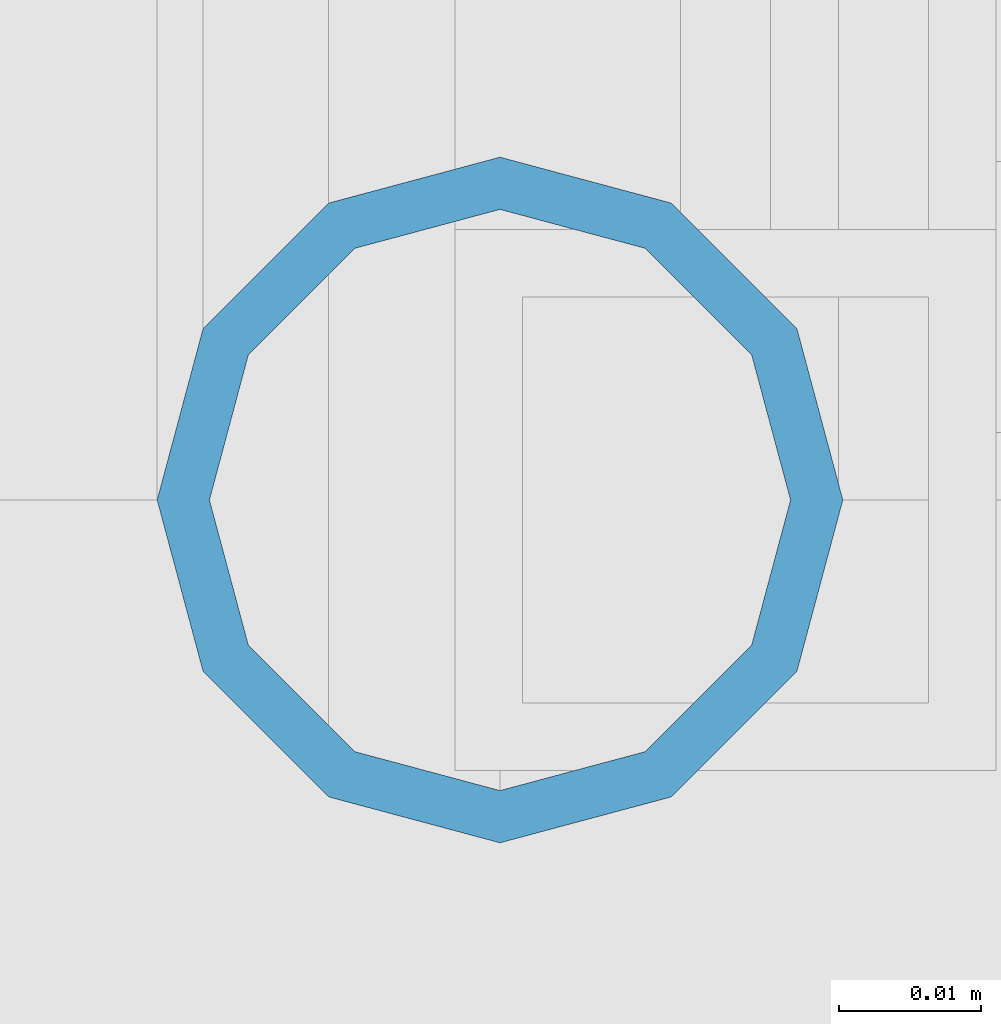
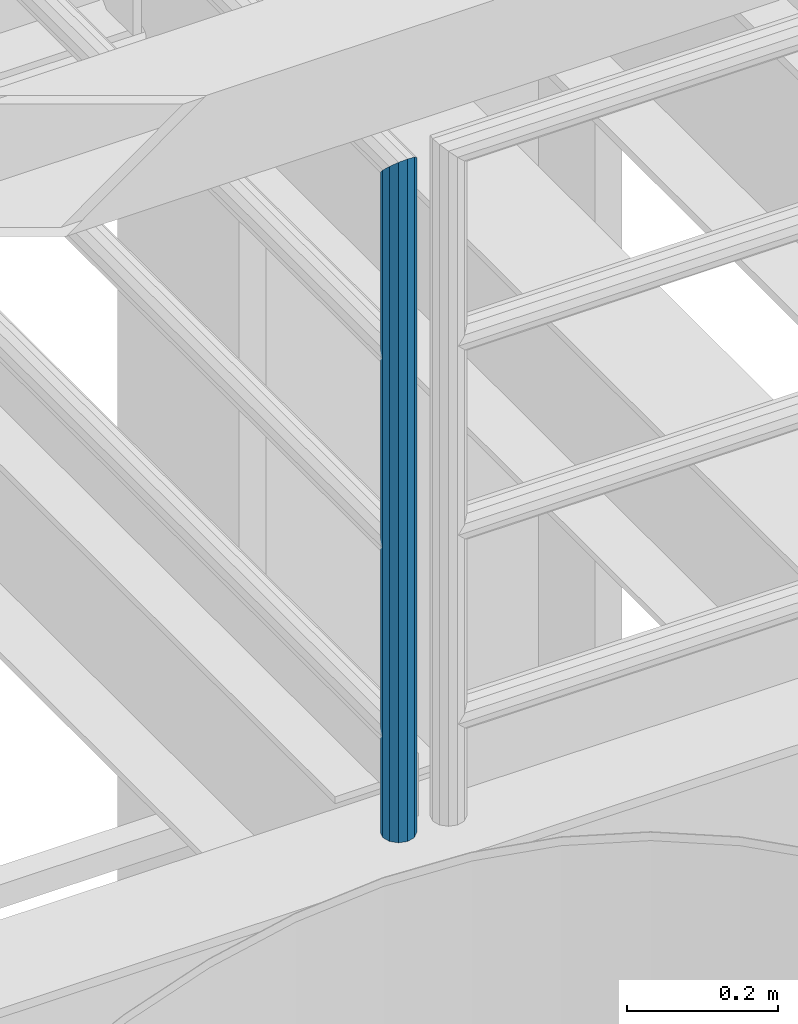
# One storey, part 586 of 1876: 1 column, 1 element without a shape of its own.
"""IFC2X3 building model written with IfcOpenShell, lengths in millimetres."""

from ifc_helpers import new_model, si_unit, frame, origin_with_axes, place, context, subcontext, project, spatial, faceted_brep, material, type_object, element, aggregate, save


model = new_model("IFC2X3")

# Units and contexts
model_context = context("Model", 3, precision=1e-05, world=origin_with_axes())
body_context = subcontext(model_context, "Body", "Model", "MODEL_VIEW")
ifc_project = project(units=[si_unit("LENGTHUNIT", "METRE", prefix="MILLI"), si_unit("AREAUNIT", "SQUARE_METRE"), si_unit("VOLUMEUNIT", "CUBIC_METRE"), si_unit("MASSUNIT", "GRAM", prefix="KILO"), si_unit("TIMEUNIT", "SECOND"), si_unit("PLANEANGLEUNIT", "RADIAN"), si_unit("SOLIDANGLEUNIT", "STERADIAN"), si_unit("THERMODYNAMICTEMPERATUREUNIT", "DEGREE_CELSIUS"), si_unit("LUMINOUSINTENSITYUNIT", "LUMEN")], contexts=[model_context])

# Site, building, storey
site_placement = place(None, origin_with_axes())
site = spatial("IfcSite", under=ifc_project, at=site_placement, CompositionType="ELEMENT")
building_placement = place(site_placement, origin_with_axes())
building = spatial("IfcBuilding", under=site, at=building_placement, Name="Undefined", CompositionType="ELEMENT")
storey_placement = place(building_placement, origin_with_axes())
storey = spatial("IfcBuildingStorey", under=building, at=storey_placement, Name="Undefined", CompositionType="ELEMENT", Elevation=0.0)

# Assembly, column
assembly_placement = place(storey_placement, origin_with_axes())
assembly = element("IfcElementAssembly", 1, at=assembly_placement, inside=storey, Name="RAIL", AssemblyPlace="NOTDEFINED", PredefinedType="RIGID_FRAME")
ifc_material = material()
column_type = type_object("IfcColumnType", Name="PIPE1-1/2SCH40", PredefinedType="NOTDEFINED")
column_placement = place(assembly_placement, frame((6197.6, -7112.0, 5130.8), z_axis=(1.0, 0.0, 0.0), x_axis=(0.0, 0.0, 1.0)))
column = element("IfcColumn", 2, at=column_placement, type_object=column_type, material=ifc_material, Name="POST", ObjectType="PIPE1-1/2SCH40", context=body_context, shape_type="Brep", body=[
    faceted_brep([(0.0, -20.4469999999999, 0.0), (0.0, -17.7076214311803, 10.2235000000001), (1058.61737856882, -17.7076214311803, 10.2235000000001), (1055.878, -20.4469999999999, 0.0), (0.0, -10.2235000000001, 17.7076214311801), (1066.1015, -10.2235000000001, 17.7076214311801), (-1.45519152283669e-11, 0.0, 20.4470000000001), (1076.325, 0.0, 20.4470000000001), (0.0, 10.2235000000001, 17.7076214311801), (1086.5485, 10.2235000000001, 17.7076214311801), (0.0, 17.7076214311803, 10.2235000000001), (1094.03262143118, 17.7076214311803, 10.2235000000001), (0.0, 20.4469999999999, 0.0), (1096.772, 20.4469999999999, 0.0), (0.0, 17.7076214311803, -10.2235000000001), (1094.03262143118, 17.7076214311803, -10.2235000000001), (0.0, 10.2235000000001, -17.7076214311801), (1086.5485, 10.2235000000001, -17.7076214311801), (-1.45519152283669e-11, 0.0, -20.4470000000001), (1076.325, 0.0, -20.4470000000001), (0.0, -10.2235000000001, -17.7076214311801), (1066.1015, -10.2235000000001, -17.7076214311801), (0.0, -17.7076214311803, -10.2235000000001), (1058.61737856882, -17.7076214311803, -10.2235000000001), (0.0, -24.1299999999992, 0.0), (0.0, -20.8971929933184, -12.0649999999996), (1055.42780700668, -20.8971929933184, -12.0649999999996), (1052.195, -24.1300000000001, 0.0), (0.0, -12.0650000000001, -20.8971929933186), (1064.26, -12.0650000000001, -20.8971929933186), (-1.45519152283669e-11, 0.0, -24.130000000001), (1076.325, 0.0, -24.1300000000001), (0.0, 12.0650000000001, -20.8971929933186), (1088.39, 12.0650000000001, -20.8971929933186), (0.0, 20.8971929933184, -12.0649999999996), (1097.22219299332, 20.8971929933184, -12.0649999999996), (0.0, 24.1299999999992, 0.0), (1100.455, 24.1300000000001, 0.0), (0.0, 20.8971929933184, 12.0649999999996), (1097.22219299332, 20.8971929933184, 12.0649999999996), (0.0, 12.0650000000001, 20.8971929933186), (1088.39, 12.0650000000001, 20.8971929933186), (-1.45519152283669e-11, 0.0, 24.130000000001), (1076.325, 0.0, 24.1300000000001), (0.0, -12.0650000000001, 20.8971929933186), (1064.26, -12.0650000000001, 20.8971929933186), (0.0, -20.8971929933184, 12.0649999999996), (1055.42780700668, -20.8971929933184, 12.0649999999996)], [[[0, 1, 2, 3]], [[1, 4, 5, 2]], [[4, 6, 7, 5]], [[6, 8, 9, 7]], [[8, 10, 11, 9]], [[10, 12, 13, 11]], [[12, 14, 15, 13]], [[14, 16, 17, 15]], [[16, 18, 19, 17]], [[18, 20, 21, 19]], [[20, 22, 23, 21]], [[22, 0, 3, 23]], [[24, 25, 26, 27]], [[25, 28, 29, 26]], [[28, 30, 31, 29]], [[30, 32, 33, 31]], [[32, 34, 35, 33]], [[34, 36, 37, 35]], [[36, 38, 39, 37]], [[38, 40, 41, 39]], [[40, 42, 43, 41]], [[42, 44, 45, 43]], [[44, 46, 47, 45]], [[46, 24, 27, 47]], [[29, 31, 33, 35, 37, 39, 41, 43, 45, 47, 27, 26], [5, 7, 9, 11, 13, 15, 17, 19, 21, 23, 3, 2]], [[46, 44, 42, 40, 38, 36, 34, 32, 30, 28, 25, 24], [22, 20, 18, 16, 14, 12, 10, 8, 6, 4, 1, 0]]]),
])
aggregate(assembly, [column])

save(model, "model.ifc")
